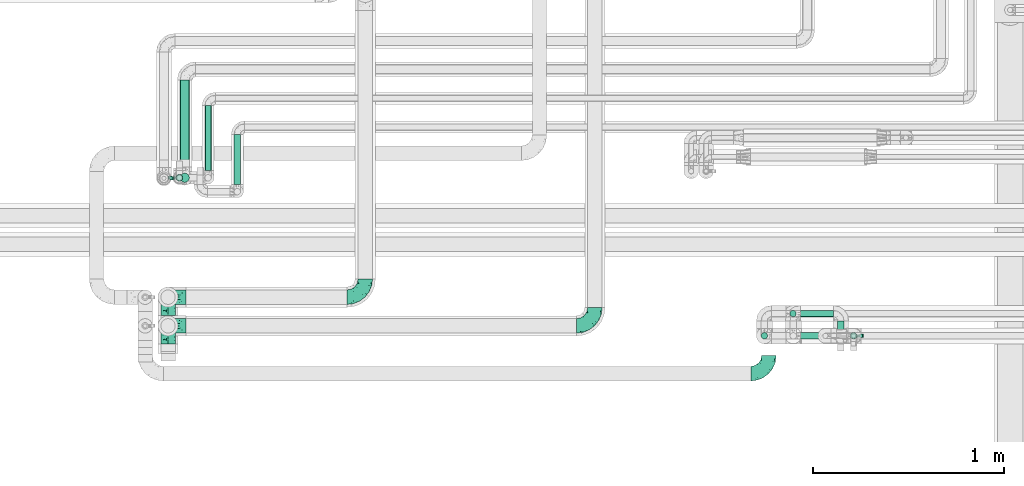
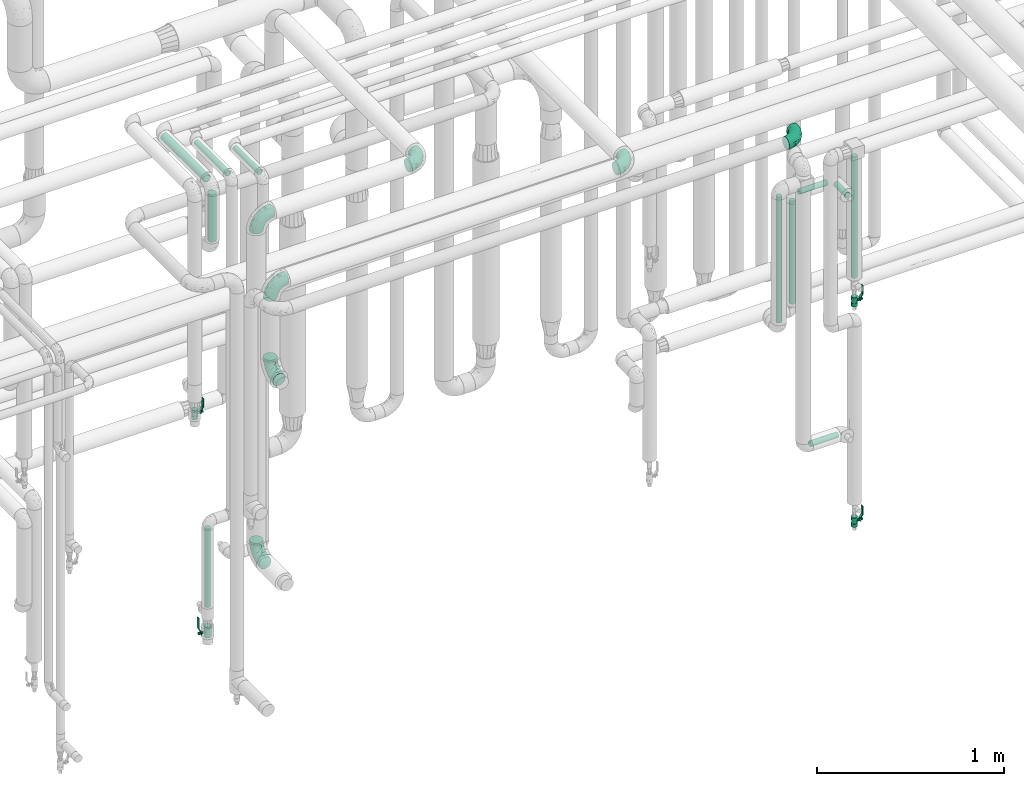
# One storey, part 702 of 827: 11 flow segments, 7 flow fittings, 4 flow controllers.
"""IFC2X3 building model written with IfcOpenShell, lengths in millimetres."""

from ifc_helpers import new_model, entity, si_unit, converted_unit, derived_unit, direction, frame, origin, origin_2d_with_axis, place, context, subcontext, project, spatial, polyline, circle, outline, extrude, faceted_brep, source, transform, mapped, material, material_list, type_object, type_shapes, element, save


model = new_model("IFC2X3")

# Units and contexts
model_context = context("Model", 3, precision=0.01, world=origin(), true_north=direction((6.12303176911189e-17, 1.0)))
body_context = subcontext(model_context, "Body", "Model", "MODEL_VIEW")
ifc_project = project(units=[si_unit("LENGTHUNIT", "METRE", prefix="MILLI"), si_unit("AREAUNIT", "SQUARE_METRE"), si_unit("VOLUMEUNIT", "CUBIC_METRE"), converted_unit("PLANEANGLEUNIT", "DEGREE", entity("IfcRatioMeasure", 0.0174532925199433), si_unit("PLANEANGLEUNIT", "RADIAN"), dimensions=[0, 0, 0, 0, 0, 0, 0]), si_unit("MASSUNIT", "GRAM", prefix="KILO"), derived_unit("MASSDENSITYUNIT", [(si_unit("MASSUNIT", "GRAM", prefix="KILO"), 1), (si_unit("LENGTHUNIT", "METRE"), -3)]), derived_unit("MOMENTOFINERTIAUNIT", [(si_unit("LENGTHUNIT", "METRE"), 4)]), si_unit("TIMEUNIT", "SECOND"), si_unit("FREQUENCYUNIT", "HERTZ"), si_unit("THERMODYNAMICTEMPERATUREUNIT", "DEGREE_CELSIUS"), derived_unit("THERMALTRANSMITTANCEUNIT", [(si_unit("MASSUNIT", "GRAM", prefix="KILO"), 1), (si_unit("THERMODYNAMICTEMPERATUREUNIT", "KELVIN"), -1), (si_unit("TIMEUNIT", "SECOND"), -3)]), derived_unit("VOLUMETRICFLOWRATEUNIT", [(si_unit("LENGTHUNIT", "METRE"), 3), (si_unit("TIMEUNIT", "SECOND"), -1)]), derived_unit("MASSFLOWRATEUNIT", [(si_unit("MASSUNIT", "GRAM", prefix="KILO"), 1), (si_unit("TIMEUNIT", "SECOND"), -1)]), derived_unit("ROTATIONALFREQUENCYUNIT", [(si_unit("TIMEUNIT", "SECOND"), -1)]), si_unit("ELECTRICCURRENTUNIT", "AMPERE"), si_unit("ELECTRICVOLTAGEUNIT", "VOLT"), si_unit("POWERUNIT", "WATT"), si_unit("FORCEUNIT", "NEWTON", prefix="KILO"), si_unit("ILLUMINANCEUNIT", "LUX"), si_unit("LUMINOUSFLUXUNIT", "LUMEN"), si_unit("LUMINOUSINTENSITYUNIT", "CANDELA"), derived_unit("USERDEFINED", [(si_unit("MASSUNIT", "GRAM", prefix="KILO"), -1), (si_unit("LENGTHUNIT", "METRE"), -2), (si_unit("TIMEUNIT", "SECOND"), 3), (si_unit("LUMINOUSFLUXUNIT", "LUMEN"), 1)]), derived_unit("LINEARVELOCITYUNIT", [(si_unit("LENGTHUNIT", "METRE"), 1), (si_unit("TIMEUNIT", "SECOND"), -1)]), si_unit("PRESSUREUNIT", "PASCAL"), derived_unit("USERDEFINED", [(si_unit("LENGTHUNIT", "METRE"), -2), (si_unit("MASSUNIT", "GRAM", prefix="KILO"), 1), (si_unit("TIMEUNIT", "SECOND"), -2)]), derived_unit("LINEARFORCEUNIT", [(si_unit("MASSUNIT", "GRAM", prefix="KILO"), 1), (si_unit("LENGTHUNIT", "METRE"), 1), (si_unit("TIMEUNIT", "SECOND"), -2), (si_unit("LENGTHUNIT", "METRE"), -1)]), derived_unit("PLANARFORCEUNIT", [(si_unit("MASSUNIT", "GRAM", prefix="KILO"), 1), (si_unit("LENGTHUNIT", "METRE"), 1), (si_unit("TIMEUNIT", "SECOND"), -2), (si_unit("LENGTHUNIT", "METRE"), -2)])], contexts=[model_context])

# Site, building, storey
site_placement = place(None, origin())
site = spatial("IfcSite", under=ifc_project, at=site_placement, CompositionType="ELEMENT")
building_placement = place(site_placement, origin())
building = spatial("IfcBuilding", under=site, at=building_placement, CompositionType="ELEMENT")
storey_placement = place(building_placement, frame((0.0, 0.0, 28200.0)))
storey = spatial("IfcBuildingStorey", under=building, at=storey_placement, Name="08", CompositionType="ELEMENT", Elevation=28200.0)

# Flow segments
pipe_segment_type = type_object("IfcPipeSegmentType", PredefinedType="NOTDEFINED")
flow_segment_1_placement = place(storey_placement, frame((59322.12, 15425.86, 1868.01)))
element("IfcFlowSegment", 1, at=flow_segment_1_placement, inside=storey, type_object=pipe_segment_type, context=body_context, shape_type="SweptSolid", body=[
    extrude(circle(Radius=16.75, at=origin_2d_with_axis()), frame((18.35, 18.35, 0.0)), (0.0, 0.0, 1.0), 793.987023342036),
])
flow_segment_2_placement = place(storey_placement, frame((59063.14, 15425.86, 852.17)))
element("IfcFlowSegment", 2, at=flow_segment_2_placement, inside=storey, type_object=pipe_segment_type, context=body_context, shape_type="SweptSolid", body=[
    extrude(circle(Radius=16.75, at=origin_2d_with_axis()), frame((0.0, 18.35, 18.35), z_axis=(1.0, 0.0, 0.0), x_axis=(0.0, -1.0, 0.0)), (0.0, 0.0, 1.0), 172.217361032213),
])
flow_segment_3_placement = place(storey_placement, frame((58855.54, 15425.86, 1738.53)))
element("IfcFlowSegment", 3, at=flow_segment_3_placement, inside=storey, type_object=pipe_segment_type, context=body_context, shape_type="SweptSolid", body=[
    extrude(circle(Radius=16.75, at=origin_2d_with_axis()), frame((18.35, 18.35, 0.0)), (0.0, 0.0, 1.0), 823.470090868733),
])
flow_segment_4_placement = place(storey_placement, frame((59005.54, 15542.12, 1738.53)))
element("IfcFlowSegment", 4, at=flow_segment_4_placement, inside=storey, type_object=pipe_segment_type, context=body_context, shape_type="SweptSolid", body=[
    extrude(circle(Radius=16.75, at=origin_2d_with_axis()), frame((18.35, 18.35, 0.0), z_axis=(0.0, 0.0, 1.0), x_axis=(-1.0, 0.0, 0.0)), (0.0, 0.0, 1.0), 674.000039895076),
])
flow_segment_5_placement = place(storey_placement, frame((59061.89, 15542.18, 2432.18)))
element("IfcFlowSegment", 5, at=flow_segment_5_placement, inside=storey, type_object=pipe_segment_type, context=body_context, shape_type="SweptSolid", body=[
    extrude(circle(Radius=16.75, at=origin_2d_with_axis()), frame((0.0, 18.35, 18.35), z_axis=(1.0, 0.0, 0.0), x_axis=(0.0, -1.0, 0.0)), (0.0, 0.0, 1.0), 173.467361032217),
])
flow_segment_6_placement = place(storey_placement, frame((59255.01, 15402.52, 2432.18)))
element("IfcFlowSegment", 6, at=flow_segment_6_placement, inside=storey, type_object=pipe_segment_type, context=body_context, shape_type="SweptSolid", body=[
    extrude(circle(Radius=16.75, at=origin_2d_with_axis()), frame((18.35, 0.0, 18.35), z_axis=(0.0, 1.0, 0.0), x_axis=(-1.0, 0.0, 0.0)), (0.0, 0.0, 1.0), 119.999999999986),
])
flow_segment_7_placement = place(storey_placement, frame((55817.54, 16327.44, 3174.4)))
element("IfcFlowSegment", 7, at=flow_segment_7_placement, inside=storey, type_object=pipe_segment_type, context=body_context, shape_type="SweptSolid", body=[
    extrude(circle(Radius=24.0, at=origin_2d_with_axis()), frame((25.6, 0.0, 25.6), z_axis=(0.0, 1.0, 0.0), x_axis=(-1.0, 0.0, 0.0)), (0.0, 0.0, 1.0), 453.499999999986),
])
flow_segment_8_placement = place(storey_placement, frame((55947.01, 16308.44, 3181.65)))
element("IfcFlowSegment", 8, at=flow_segment_8_placement, inside=storey, type_object=pipe_segment_type, context=body_context, shape_type="SweptSolid", body=[
    extrude(circle(Radius=16.75, at=origin_2d_with_axis()), frame((18.35, 0.0, 18.35), z_axis=(0.0, 1.0, 0.0), x_axis=(-1.0, 0.0, 0.0)), (0.0, 0.0, 1.0), 339.25941269584),
])
flow_segment_9_placement = place(storey_placement, frame((56099.79, 16235.94, 3181.65)))
element("IfcFlowSegment", 9, at=flow_segment_9_placement, inside=storey, type_object=pipe_segment_type, context=body_context, shape_type="SweptSolid", body=[
    extrude(circle(Radius=16.75, at=origin_2d_with_axis()), frame((18.35, 0.0, 18.35), z_axis=(0.0, 1.0, 0.0), x_axis=(-1.0, 0.0, 0.0)), (0.0, 0.0, 1.0), 261.759412695868),
])
flow_segment_10_placement = place(storey_placement, frame((55817.54, 16244.84, 2832.0)))
element("IfcFlowSegment", 10, at=flow_segment_10_placement, inside=storey, type_object=pipe_segment_type, context=body_context, shape_type="SweptSolid", body=[
    extrude(circle(Radius=24.0, at=origin_2d_with_axis()), frame((25.6, 25.6, 0.0)), (0.0, 0.0, 1.0), 310.999999999973),
])
flow_segment_11_placement = place(storey_placement, frame((55797.01, 16252.09, 446.5)))
element("IfcFlowSegment", 11, at=flow_segment_11_placement, inside=storey, type_object=pipe_segment_type, context=body_context, shape_type="SweptSolid", body=[
    extrude(circle(Radius=16.75, at=origin_2d_with_axis()), frame((18.35, 18.35, 0.0)), (0.0, 0.0, 1.0), 515.500000000004),
])

# Flow controllers
ifc_material = material()
ifc_material_list = material_list([ifc_material, ifc_material, ifc_material, ifc_material, ifc_material])
valve_type_1 = type_object("IfcValveType", PredefinedType="NOTDEFINED", material=ifc_material_list)
shared_shape_1 = source(origin(), body_context, "Body", "SweptSolid", [
    extrude(circle(Radius=17.5, at=origin_2d_with_axis()), frame((-30.5, 0.0, 0.0), z_axis=(1.0, 0.0, 0.0), x_axis=(0.0, 1.0, 0.0)), (0.0, 0.0, 1.0), 20.3333333333333),
    extrude(circle(Radius=16.0, at=origin_2d_with_axis()), frame((-10.17, 0.0, 0.0), z_axis=(1.0, 0.0, 0.0), x_axis=(0.0, 1.0, 0.0)), (0.0, 0.0, 1.0), 20.3333333333333),
    extrude(circle(Radius=17.5, at=origin_2d_with_axis()), frame((10.17, 0.0, 0.0), z_axis=(1.0, 0.0, 0.0), x_axis=(0.0, 1.0, 0.0)), (0.0, 0.0, 1.0), 20.3333333333333),
    extrude(outline(polyline([(-38.75, -5.0), (-38.75, -10.0), (-17.92, -10.0), (2.08, 5.0), (56.25, 5.0), (56.25, 10.0), (0.42, 10.0), (-19.58, -5.0), (-38.75, -5.0)])), frame((28.75, -8.75, 41.5), z_axis=(0.0, -1.0, 0.0), x_axis=(1.0, 0.0, 0.0)), (0.0, 0.0, -1.0), 17.5),
    extrude(circle(Radius=8.0, at=origin_2d_with_axis()), origin(), (0.0, 0.0, 1.0), 49.0),
])
type_shapes(valve_type_1, [shared_shape_1])
for number, where, z_axis, x_axis in (
    (12, (55734.18, 16267.94, 1734.66), (1.0, 0.0, 0.0), (0.0, 0.0, 1.0)),
    (13, (59340.46, 15444.21, 1710.51), (1.0, 0.0, 0.0), (0.0, 0.0, 1.0)),
    (14, (59340.46, 15444.21, 269.05), (1.0, 0.0, 0.0), (0.0, 0.0, 1.0)),
):
    element("IfcFlowController", number, at=place(storey_placement, frame(where, z_axis=z_axis, x_axis=x_axis)), inside=storey, type_object=valve_type_1, material=ifc_material, context=body_context, shape_type="MappedRepresentation", body=[
        mapped(shared_shape_1, transform((0.0, 0.0, 0.0), scale=1.0)),
    ])
valve_type_2 = type_object("IfcValveType", PredefinedType="NOTDEFINED", material=ifc_material_list)
shared_shape_2 = source(origin(), body_context, "Body", "SweptSolid", [
    extrude(circle(Radius=20.0, at=origin_2d_with_axis()), frame((-35.0, 0.0, 0.0), z_axis=(1.0, 0.0, 0.0), x_axis=(0.0, 1.0, 0.0)), (0.0, 0.0, 1.0), 23.3333333333333),
    extrude(circle(Radius=20.0, at=origin_2d_with_axis()), frame((-11.67, 0.0, 0.0), z_axis=(1.0, 0.0, 0.0), x_axis=(0.0, 1.0, 0.0)), (0.0, 0.0, 1.0), 23.3333333333333),
    extrude(circle(Radius=20.0, at=origin_2d_with_axis()), frame((11.67, 0.0, 0.0), z_axis=(1.0, 0.0, 0.0), x_axis=(0.0, 1.0, 0.0)), (0.0, 0.0, 1.0), 23.3333333333333),
    extrude(outline(polyline([(-44.88, -5.0), (-44.88, -10.0), (-24.17, -10.0), (0.33, 5.0), (70.12, 5.0), (70.12, 10.0), (-1.08, 10.0), (-25.58, -5.0), (-44.88, -5.0)])), frame((34.88, -10.0, 49.5), z_axis=(0.0, -1.0, 0.0), x_axis=(1.0, 0.0, 0.0)), (0.0, 0.0, -1.0), 20.0),
    extrude(circle(Radius=8.0, at=origin_2d_with_axis()), origin(), (0.0, 0.0, 1.0), 57.0),
])
type_shapes(valve_type_2, [shared_shape_2])
flow_controller_placement = place(storey_placement, frame((55815.36, 16270.44, 284.5), z_axis=(-1.0, 0.0, 0.0), x_axis=(0.0, 0.0, 1.0)))
element("IfcFlowController", 15, at=flow_controller_placement, inside=storey, type_object=valve_type_2, material=ifc_material, context=body_context, shape_type="MappedRepresentation", body=[
    mapped(shared_shape_2, transform((0.0, 0.0, 0.0), scale=1.0)),
])

# Flow fittings
pipe_fitting_type = type_object("IfcPipeFittingType", Name="ADSK_1", PredefinedType="NOTDEFINED", material=ifc_material)
shared_shape_3 = source(origin(), body_context, "Body", "Brep", [
    faceted_brep([(-95.0, 19.02, -32.95), (-95.0, 9.85, -36.75), (-95.0, 0.0, -38.05), (-95.0, -9.85, -36.75), (-95.0, -19.03, -32.95), (-95.0, -26.91, -26.91), (-95.0, -32.95, -19.03), (-95.0, -36.75, -9.85), (-95.0, -38.05, 0.0), (-95.0, -36.75, 9.85), (-95.0, -32.95, 19.02), (-95.0, -26.91, 26.91), (-95.0, -19.03, 32.95), (-95.0, -9.85, 36.75), (-95.0, 0.0, 38.05), (-95.0, 9.85, 36.75), (-95.0, 19.02, 32.95), (-95.0, 26.91, 26.91), (-95.0, 32.95, 19.02), (-95.0, 36.75, 9.85), (-95.0, 38.05, 0.0), (-95.0, 36.75, -9.85), (-95.0, 32.95, -19.03), (-95.0, 26.91, -26.91), (0.0, 95.0, -38.05), (-9.85, 95.0, -36.75), (-19.02, 95.0, -32.95), (-26.91, 95.0, -26.91), (-32.95, 95.0, -19.03), (-36.75, 95.0, -9.85), (-38.05, 95.0, 0.0), (-36.75, 95.0, 9.85), (-32.95, 95.0, 19.02), (-26.91, 95.0, 26.91), (-19.02, 95.0, 32.95), (-9.85, 95.0, 36.75), (0.0, 95.0, 38.05), (9.85, 95.0, 36.75), (19.03, 95.0, 32.95), (26.91, 95.0, 26.91), (32.95, 95.0, 19.02), (36.75, 95.0, 9.85), (38.05, 95.0, 0.0), (36.75, 95.0, -9.85), (32.95, 95.0, -19.03), (26.91, 95.0, -26.91), (19.03, 95.0, -32.95), (9.85, 95.0, -36.75), (-7.99, -4.96, 6.3), (-0.92, 0.92, 0.0), (4.62, 8.1, 8.01), (-76.19, -35.57, 0.0), (-64.32, -32.32, 12.43), (20.51, 62.45, 28.68), (-60.56, -33.52, 0.0), (-70.4, -13.47, 34.42), (-39.61, -5.88, 32.32), (-49.6, 2.07, 37.1), (-70.34, -28.81, 21.71), (14.64, 40.81, 26.5), (5.88, 39.61, 32.32), (3.59, 20.77, 25.31), (-40.45, 68.06, 16.75), (-62.45, -20.51, 28.68), (-44.52, -26.87, 0.0), (-28.47, -20.22, 0.0), (-26.43, -17.83, 8.75), (-76.1, 39.63, 10.76), (-72.74, 37.58, 18.19), (-60.35, 46.18, 14.61), (-13.4, 13.4, 32.12), (-20.77, -3.59, 25.31), (-14.66, 81.47, 35.56), (-6.22, 71.26, 37.92), (-57.5, 42.48, 22.79), (-15.0, 34.74, 37.7), (-27.1, 12.08, 36.05), (-9.2, 28.81, 35.63), (-79.98, 23.7, 30.95), (-73.68, -4.3, 37.48), (-30.74, 21.67, 37.97), (-62.36, 47.59, 6.79), (-72.71, 32.83, 24.69), (-67.42, 7.02, 37.95), (-32.13, 75.27, 24.51), (-43.46, 51.47, 26.26), (-24.98, 73.15, 31.29), (20.59, 41.28, 19.85), (7.79, 16.09, 15.86), (-73.21, 42.39, 0.0), (-54.73, 54.73, 0.0), (-73.44, 15.79, 35.79), (-5.94, 4.32, 20.43), (28.81, 70.34, 21.71), (32.32, 64.32, 12.43), (-53.59, 26.2, 35.09), (-52.02, 19.31, 37.21), (21.38, 33.53, 10.34), (26.87, 44.52, 0.0), (-48.28, 12.14, 38.05), (4.3, 73.68, 37.48), (-44.08, -25.52, 12.79), (-41.28, -20.59, 19.85), (35.57, 76.19, 0.0), (-47.26, 54.3, 20.18), (-47.4, 61.99, 8.58), (-42.39, 73.21, 0.0), (-39.67, 78.86, 7.21), (-45.69, 36.84, 33.11), (-32.83, 50.13, 33.35), (13.47, 70.4, 34.42), (-18.25, 63.73, 36.07), (-40.63, -13.75, 27.22), (-16.63, 46.37, 37.95), (-53.47, 38.79, 28.59), (-26.07, 48.54, 36.15), (-34.51, 34.51, 36.86), (-2.07, 49.6, 37.1), (-22.79, -10.49, 19.23), (-61.73, 28.67, 31.87), (9.65, 14.7, 0.0), (20.22, 28.47, 0.0), (33.52, 60.56, 0.0), (-11.42, -5.44, 13.25), (-14.7, -9.65, 0.0), (-81.47, 14.66, -35.56), (-62.45, -20.51, -28.68), (-71.26, 6.22, -37.92), (-75.27, 32.13, -24.51), (-73.15, 24.98, -31.29), (13.47, 70.4, -34.42), (5.88, 39.61, -32.32), (-2.07, 49.6, -37.1), (-78.86, 39.67, -7.21), (-70.4, -13.47, -34.42), (-39.61, -5.88, -32.32), (-61.99, 47.4, -8.58), (32.32, 64.32, -12.43), (28.81, 70.34, -21.71), (-63.73, 18.25, -36.07), (-50.13, 32.83, -33.35), (4.3, 73.68, -37.48), (-7.02, 67.42, -37.95), (-39.63, 76.1, -10.76), (-46.18, 60.35, -14.61), (-47.59, 62.36, -6.79), (-64.32, -32.32, -12.43), (-26.2, 53.59, -35.09), (-15.79, 73.44, -35.79), (-19.31, 52.02, -37.21), (-37.58, 72.74, -18.19), (-70.34, -28.81, -21.71), (-42.48, 57.5, -22.79), (-38.79, 53.47, -28.59), (-51.47, 43.46, -26.26), (-32.83, 72.71, -24.69), (-46.37, 16.63, -37.95), (-73.68, -4.3, -37.48), (-41.28, -20.59, -19.85), (-44.08, -25.52, -12.79), (13.75, 40.63, -27.22), (20.51, 62.45, -28.68), (-68.06, 40.45, -16.75), (-54.3, 47.26, -20.18), (-12.14, 48.28, -38.05), (-21.67, 30.74, -37.97), (-36.84, 45.69, -33.11), (-11.42, -5.44, -13.25), (7.79, 16.09, -15.86), (4.62, 8.1, -8.01), (-23.7, 79.98, -30.95), (-26.43, -17.83, -8.75), (-7.99, -4.96, -6.3), (-40.81, -14.64, -26.5), (-20.77, -3.59, -25.31), (-34.74, 15.0, -37.7), (-12.08, 27.1, -36.05), (-28.81, 9.2, -35.63), (-22.79, -10.49, -19.23), (21.38, 33.53, -10.34), (20.59, 41.28, -19.85), (-48.54, 26.07, -36.15), (-49.6, 2.07, -37.1), (-13.4, 13.4, -32.12), (3.59, 20.77, -25.31), (-28.67, 61.73, -31.87), (-34.51, 34.51, -36.86), (-5.94, 4.32, -20.43)], [[[0, 1, 2, 3, 4, 5, 6, 7, 8, 9, 10, 11, 12, 13, 14, 15, 16, 17, 18, 19, 20, 21, 22, 23]], [[24, 25, 26, 27, 28, 29, 30, 31, 32, 33, 34, 35, 36, 37, 38, 39, 40, 41, 42, 43, 44, 45, 46, 47]], [[48, 49, 50]], [[51, 52, 9]], [[53, 39, 38]], [[9, 52, 10]], [[54, 52, 51]], [[55, 56, 57]], [[11, 10, 58]], [[59, 60, 61]], [[32, 31, 62]], [[63, 12, 11]], [[63, 55, 12]], [[64, 65, 66]], [[67, 68, 69]], [[70, 56, 71]], [[35, 72, 73]], [[69, 68, 74]], [[75, 76, 77]], [[16, 78, 17]], [[13, 79, 14]], [[76, 75, 80]], [[67, 69, 81]], [[18, 17, 82]], [[14, 79, 83]], [[20, 19, 67]], [[84, 85, 86]], [[87, 61, 88]], [[89, 81, 90]], [[18, 82, 68]], [[15, 91, 16]], [[14, 83, 15]], [[71, 92, 61]], [[17, 78, 82]], [[93, 87, 94]], [[95, 91, 96]], [[97, 98, 94]], [[86, 72, 34]], [[96, 99, 80]], [[37, 36, 100]], [[40, 39, 93]], [[40, 94, 41]], [[64, 66, 101]], [[93, 94, 40]], [[58, 102, 63]], [[94, 103, 41]], [[94, 87, 97]], [[104, 69, 74]], [[34, 33, 86]], [[105, 69, 104]], [[52, 58, 10]], [[106, 107, 30]], [[108, 109, 85]], [[105, 106, 90]], [[53, 110, 60]], [[86, 111, 72]], [[86, 109, 111]], [[33, 84, 86]], [[12, 55, 13]], [[112, 56, 63]], [[110, 38, 37]], [[34, 72, 35]], [[36, 35, 73]], [[111, 113, 73]], [[105, 107, 106]], [[110, 53, 38]], [[74, 114, 85]], [[91, 15, 83]], [[105, 90, 81]], [[107, 62, 31]], [[33, 32, 84]], [[115, 109, 116]], [[111, 115, 113]], [[100, 73, 117]], [[56, 55, 63]], [[79, 55, 57]], [[102, 118, 112]], [[56, 70, 76]], [[100, 110, 37]], [[117, 77, 60]], [[117, 60, 110]], [[60, 70, 61]], [[58, 52, 101]], [[63, 11, 58]], [[39, 53, 93]], [[87, 93, 53]], [[96, 91, 83]], [[78, 91, 119]], [[32, 62, 84]], [[84, 62, 104]], [[86, 85, 109]], [[85, 114, 108]], [[80, 113, 116]], [[117, 73, 113]], [[80, 116, 96]], [[80, 57, 76]], [[71, 112, 118]], [[61, 87, 59]], [[62, 107, 105]], [[97, 120, 121]], [[70, 71, 61]], [[71, 118, 92]], [[73, 100, 36]], [[110, 100, 117]], [[55, 79, 13]], [[83, 79, 57]], [[96, 83, 99]], [[116, 108, 95]], [[50, 97, 88]], [[97, 87, 88]], [[50, 49, 120]], [[122, 94, 98]], [[89, 20, 67]], [[105, 81, 69]], [[89, 67, 81]], [[68, 19, 18]], [[68, 67, 19]], [[74, 68, 82]], [[114, 82, 119]], [[74, 85, 104]], [[82, 114, 74]], [[114, 119, 108]], [[95, 108, 119]], [[116, 109, 108]], [[123, 48, 50]], [[97, 50, 120]], [[123, 50, 88]], [[91, 95, 119]], [[116, 95, 96]], [[84, 104, 85]], [[104, 62, 105]], [[83, 57, 99]], [[57, 80, 99]], [[66, 48, 123]], [[66, 124, 48]], [[118, 66, 123]], [[124, 66, 65]], [[66, 118, 101]], [[54, 64, 52]], [[124, 49, 48]], [[30, 107, 31]], [[91, 78, 16]], [[82, 78, 119]], [[56, 76, 57]], [[77, 76, 70]], [[60, 77, 70]], [[77, 117, 75]], [[117, 113, 75]], [[113, 80, 75]], [[9, 8, 51]], [[103, 94, 122]], [[103, 42, 41]], [[73, 72, 111]], [[113, 115, 116]], [[111, 109, 115]], [[102, 112, 63]], [[71, 56, 112]], [[118, 102, 101]], [[92, 123, 88]], [[123, 92, 118]], [[61, 92, 88]], [[87, 53, 59]], [[60, 59, 53]], [[97, 121, 98]], [[58, 101, 102]], [[64, 101, 52]], [[125, 1, 0]], [[126, 5, 4]], [[2, 1, 127]], [[1, 125, 127]], [[128, 129, 23]], [[130, 131, 132]], [[89, 133, 20]], [[126, 134, 135]], [[136, 89, 90]], [[137, 138, 44]], [[139, 129, 140]], [[24, 141, 142]], [[143, 144, 145]], [[125, 129, 139]], [[6, 146, 7]], [[147, 148, 149]], [[146, 51, 7]], [[143, 150, 144]], [[146, 6, 151]], [[152, 153, 154]], [[126, 4, 134]], [[0, 23, 129]], [[28, 155, 150]], [[43, 42, 103]], [[54, 146, 64]], [[139, 156, 127]], [[157, 3, 2]], [[151, 158, 159]], [[160, 131, 161]], [[22, 21, 162]], [[136, 144, 163]], [[149, 164, 165]], [[24, 142, 25]], [[166, 140, 154]], [[154, 129, 128]], [[143, 30, 29]], [[167, 168, 169]], [[155, 28, 27]], [[26, 170, 27]], [[171, 167, 172]], [[26, 25, 148]], [[27, 170, 155]], [[173, 135, 174]], [[144, 150, 152]], [[175, 176, 177]], [[24, 47, 141]], [[45, 161, 46]], [[148, 25, 142]], [[176, 175, 165]], [[64, 159, 171]], [[138, 45, 44]], [[130, 46, 161]], [[137, 44, 43]], [[178, 159, 158]], [[137, 103, 122]], [[163, 144, 152]], [[136, 133, 89]], [[103, 137, 43]], [[6, 5, 151]], [[178, 158, 173]], [[134, 4, 3]], [[178, 173, 174]], [[137, 98, 179]], [[145, 90, 106]], [[138, 180, 161]], [[46, 130, 47]], [[136, 90, 145]], [[133, 162, 21]], [[23, 22, 128]], [[139, 140, 181]], [[139, 181, 156]], [[157, 127, 182]], [[157, 134, 3]], [[182, 177, 135]], [[182, 135, 134]], [[135, 183, 174]], [[131, 130, 161]], [[141, 130, 132]], [[160, 180, 184]], [[131, 183, 176]], [[5, 126, 151]], [[158, 151, 126]], [[180, 138, 137]], [[161, 45, 138]], [[149, 148, 142]], [[170, 148, 185]], [[22, 162, 128]], [[128, 162, 163]], [[129, 154, 140]], [[154, 153, 166]], [[165, 156, 186]], [[182, 127, 156]], [[165, 186, 149]], [[165, 132, 176]], [[131, 184, 183]], [[187, 167, 178]], [[184, 168, 187]], [[167, 169, 172]], [[184, 180, 168]], [[174, 183, 184]], [[127, 157, 2]], [[134, 157, 182]], [[130, 141, 47]], [[142, 141, 132]], [[149, 142, 164]], [[186, 166, 147]], [[180, 179, 168]], [[169, 179, 120]], [[137, 179, 180]], [[179, 121, 120]], [[106, 30, 143]], [[136, 145, 144]], [[106, 143, 145]], [[150, 29, 28]], [[150, 143, 29]], [[152, 150, 155]], [[153, 155, 185]], [[152, 154, 163]], [[155, 153, 152]], [[153, 185, 166]], [[147, 166, 185]], [[186, 140, 166]], [[169, 120, 49]], [[169, 49, 172]], [[179, 169, 168]], [[148, 147, 185]], [[186, 147, 149]], [[128, 163, 154]], [[163, 162, 136]], [[142, 132, 164]], [[132, 165, 164]], [[171, 124, 65]], [[124, 171, 172]], [[64, 146, 159]], [[171, 159, 178]], [[171, 65, 64]], [[172, 49, 124]], [[162, 133, 136]], [[20, 133, 21]], [[148, 170, 26]], [[155, 170, 185]], [[131, 176, 132]], [[177, 176, 183]], [[135, 177, 183]], [[177, 182, 175]], [[182, 156, 175]], [[156, 165, 175]], [[51, 146, 54]], [[51, 8, 7]], [[129, 125, 0]], [[127, 125, 139]], [[140, 186, 181]], [[156, 181, 186]], [[158, 126, 173]], [[135, 173, 126]], [[187, 178, 174]], [[171, 178, 167]], [[184, 187, 174]], [[167, 187, 168]], [[180, 160, 161]], [[184, 131, 160]], [[98, 137, 122]], [[98, 121, 179]], [[151, 159, 146]]]),
])
type_shapes(pipe_fitting_type, [shared_shape_3])
for number, where, name in (
    (16, (58897.91, 15246.2, 3050.0), "ADSK_1"),
    (17, (57987.89, 15496.2, 3050.0), "ADSK_1"),
    (18, (56787.39, 15646.2, 3400.0), "ADSK_1"),
):
    element("IfcFlowFitting", number, at=place(storey_placement, frame(where)), inside=storey, type_object=pipe_fitting_type, material=ifc_material, Name=name, ObjectType="ADSK_1", context=body_context, shape_type="MappedRepresentation", body=[
        mapped(shared_shape_3, transform((0.0, 0.0, 0.0), scale=1.0)),
    ])
for number, where, z_axis, x_axis, name in (
    (19, (55755.84, 15646.2, 3400.0), (0.0, -1.0, 0.0), (-1.0, 0.0, 0.0), "ADSK_1"),
    (20, (55755.84, 15646.2, 1185.0), (-1.0, 0.0, 0.0), (0.0, 0.0, -1.0), "ADSK_1"),
    (21, (55755.84, 15496.2, 3050.0), (0.0, -1.0, 0.0), (-1.0, 0.0, 0.0), "ADSK_1"),
    (22, (55755.84, 15496.2, 2475.0), (-1.0, 0.0, 0.0), (0.0, 0.0, -1.0), "ADSK_1"),
):
    element("IfcFlowFitting", number, at=place(storey_placement, frame(where, z_axis=z_axis, x_axis=x_axis)), inside=storey, type_object=pipe_fitting_type, material=ifc_material, Name=name, ObjectType="ADSK_1", context=body_context, shape_type="MappedRepresentation", body=[
        mapped(shared_shape_3, transform((0.0, 0.0, 0.0), scale=1.0)),
    ])

save(model, "model.ifc")
